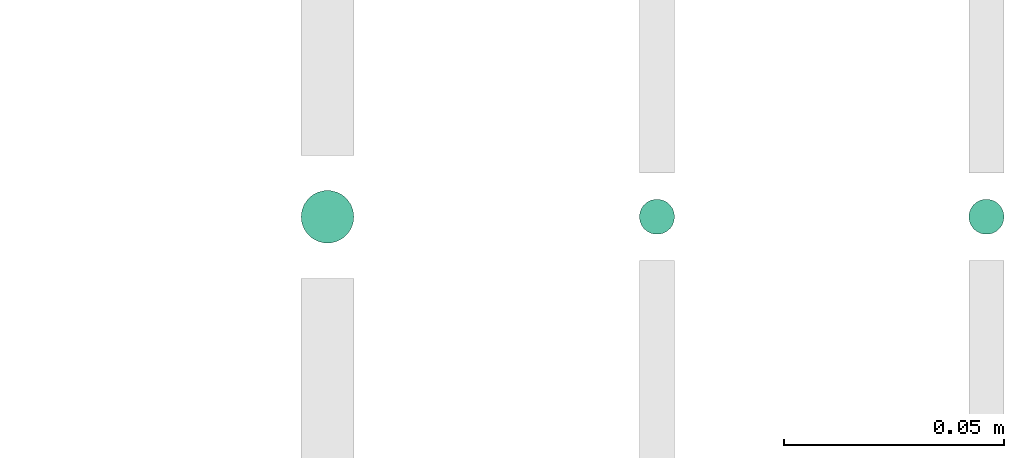
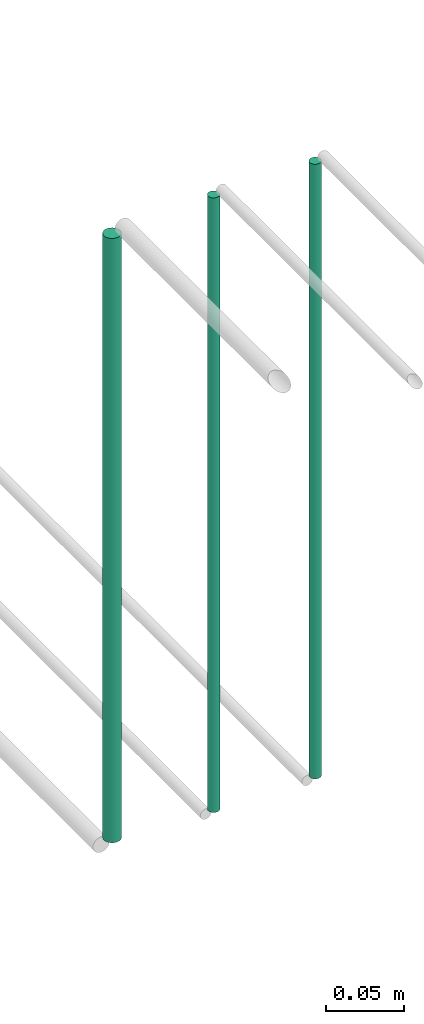
# One storey, part 228 of 331: 3 flow segments.
"""IFC2X3 building model written with IfcOpenShell, lengths in millimetres."""

from ifc_helpers import new_model, entity, si_unit, converted_unit, derived_unit, direction, frame, origin, origin_2d_with_axis, place, context, subcontext, project, spatial, circle, extrude, type_object, element, save


model = new_model("IFC2X3")

# Units and contexts
model_context = context("Model", 3, precision=0.01, world=origin(), true_north=direction((6.12303176911189e-17, 1.0)))
body_context = subcontext(model_context, "Body", "Model", "MODEL_VIEW")
ifc_project = project(units=[si_unit("LENGTHUNIT", "METRE", prefix="MILLI"), si_unit("AREAUNIT", "SQUARE_METRE"), si_unit("VOLUMEUNIT", "CUBIC_METRE"), converted_unit("PLANEANGLEUNIT", "DEGREE", entity("IfcRatioMeasure", 0.0174532925199433), si_unit("PLANEANGLEUNIT", "RADIAN"), dimensions=[0, 0, 0, 0, 0, 0, 0]), si_unit("MASSUNIT", "GRAM", prefix="KILO"), derived_unit("MASSDENSITYUNIT", [(si_unit("MASSUNIT", "GRAM", prefix="KILO"), 1), (si_unit("LENGTHUNIT", "METRE"), -3)]), derived_unit("MOMENTOFINERTIAUNIT", [(si_unit("LENGTHUNIT", "METRE"), 4)]), si_unit("TIMEUNIT", "SECOND"), si_unit("FREQUENCYUNIT", "HERTZ"), si_unit("THERMODYNAMICTEMPERATUREUNIT", "DEGREE_CELSIUS"), derived_unit("THERMALTRANSMITTANCEUNIT", [(si_unit("MASSUNIT", "GRAM", prefix="KILO"), 1), (si_unit("THERMODYNAMICTEMPERATUREUNIT", "KELVIN"), -1), (si_unit("TIMEUNIT", "SECOND"), -3)]), derived_unit("VOLUMETRICFLOWRATEUNIT", [(si_unit("LENGTHUNIT", "METRE"), 3), (si_unit("TIMEUNIT", "SECOND"), -1)]), derived_unit("MASSFLOWRATEUNIT", [(si_unit("MASSUNIT", "GRAM", prefix="KILO"), 1), (si_unit("TIMEUNIT", "SECOND"), -1)]), derived_unit("ROTATIONALFREQUENCYUNIT", [(si_unit("TIMEUNIT", "SECOND"), -1)]), si_unit("ELECTRICCURRENTUNIT", "AMPERE"), si_unit("ELECTRICVOLTAGEUNIT", "VOLT"), si_unit("POWERUNIT", "WATT"), si_unit("FORCEUNIT", "NEWTON", prefix="KILO"), si_unit("ILLUMINANCEUNIT", "LUX"), si_unit("LUMINOUSFLUXUNIT", "LUMEN"), si_unit("LUMINOUSINTENSITYUNIT", "CANDELA"), derived_unit("USERDEFINED", [(si_unit("MASSUNIT", "GRAM", prefix="KILO"), -1), (si_unit("LENGTHUNIT", "METRE"), -2), (si_unit("TIMEUNIT", "SECOND"), 3), (si_unit("LUMINOUSFLUXUNIT", "LUMEN"), 1)]), derived_unit("LINEARVELOCITYUNIT", [(si_unit("LENGTHUNIT", "METRE"), 1), (si_unit("TIMEUNIT", "SECOND"), -1)]), si_unit("PRESSUREUNIT", "PASCAL"), derived_unit("USERDEFINED", [(si_unit("LENGTHUNIT", "METRE"), -2), (si_unit("MASSUNIT", "GRAM", prefix="KILO"), 1), (si_unit("TIMEUNIT", "SECOND"), -2)]), derived_unit("LINEARFORCEUNIT", [(si_unit("MASSUNIT", "GRAM", prefix="KILO"), 1), (si_unit("LENGTHUNIT", "METRE"), 1), (si_unit("TIMEUNIT", "SECOND"), -2), (si_unit("LENGTHUNIT", "METRE"), -1)]), derived_unit("PLANARFORCEUNIT", [(si_unit("MASSUNIT", "GRAM", prefix="KILO"), 1), (si_unit("LENGTHUNIT", "METRE"), 1), (si_unit("TIMEUNIT", "SECOND"), -2), (si_unit("LENGTHUNIT", "METRE"), -2)])], contexts=[model_context])

# Site, building, storey
site_placement = place(None, frame((0.0, -0.00077364408347762, 0.0)))
site = spatial("IfcSite", under=ifc_project, at=site_placement, CompositionType="ELEMENT")
building_placement = place(site_placement, origin())
building = spatial("IfcBuilding", under=site, at=building_placement, CompositionType="ELEMENT")
storey_placement = place(building_placement, origin())
storey = spatial("IfcBuildingStorey", under=building, at=storey_placement, CompositionType="ELEMENT", Elevation=0.0)

# Flow segments
pipe_segment_type = type_object("IfcPipeSegmentType", PredefinedType="NOTDEFINED")
flow_segment_1_placement = place(storey_placement, frame((68011.5232052592, 5192.40472776409, 6764.0)))
element("IfcFlowSegment", 1, at=flow_segment_1_placement, inside=storey, type_object=pipe_segment_type, context=body_context, shape_type="SweptSolid", body=[
    extrude(circle(Radius=6.0, at=origin_2d_with_axis()), frame((7.59527223591454, 7.59527223591562, 0.0), z_axis=(0.0, 0.0, 1.0), x_axis=(-1.0, 0.0, 0.0)), (0.0, 0.0, 1.0), 472.000000000008),
])
flow_segment_2_placement = place(storey_placement, frame((68088.5232052591, 5194.40472776409, 6760.0)))
element("IfcFlowSegment", 2, at=flow_segment_2_placement, inside=storey, type_object=pipe_segment_type, context=body_context, shape_type="SweptSolid", body=[
    extrude(circle(Radius=4.0, at=origin_2d_with_axis()), frame((5.59527223591499, 5.59527223591607, 0.0), z_axis=(0.0, 0.0, 1.0), x_axis=(-1.0, 0.0, 0.0)), (0.0, 0.0, 1.0), 480.000000000009),
])
flow_segment_3_placement = place(storey_placement, frame((68163.5232052592, 5194.40537015913, 6760.0)))
element("IfcFlowSegment", 3, at=flow_segment_3_placement, inside=storey, type_object=pipe_segment_type, context=body_context, shape_type="SweptSolid", body=[
    extrude(circle(Radius=4.0, at=origin_2d_with_axis()), frame((5.59527223591499, 5.59527223591607, 0.0), z_axis=(0.0, 0.0, 1.0), x_axis=(-1.0, 0.0, 0.0)), (0.0, 0.0, 1.0), 480.0),
])

save(model, "model.ifc")
